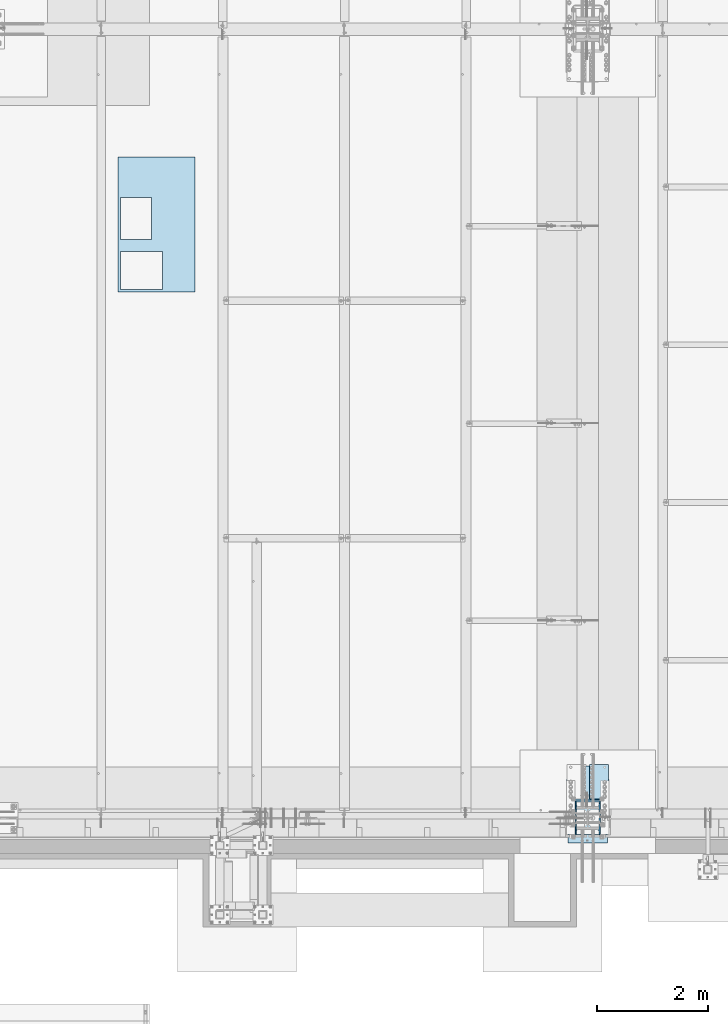
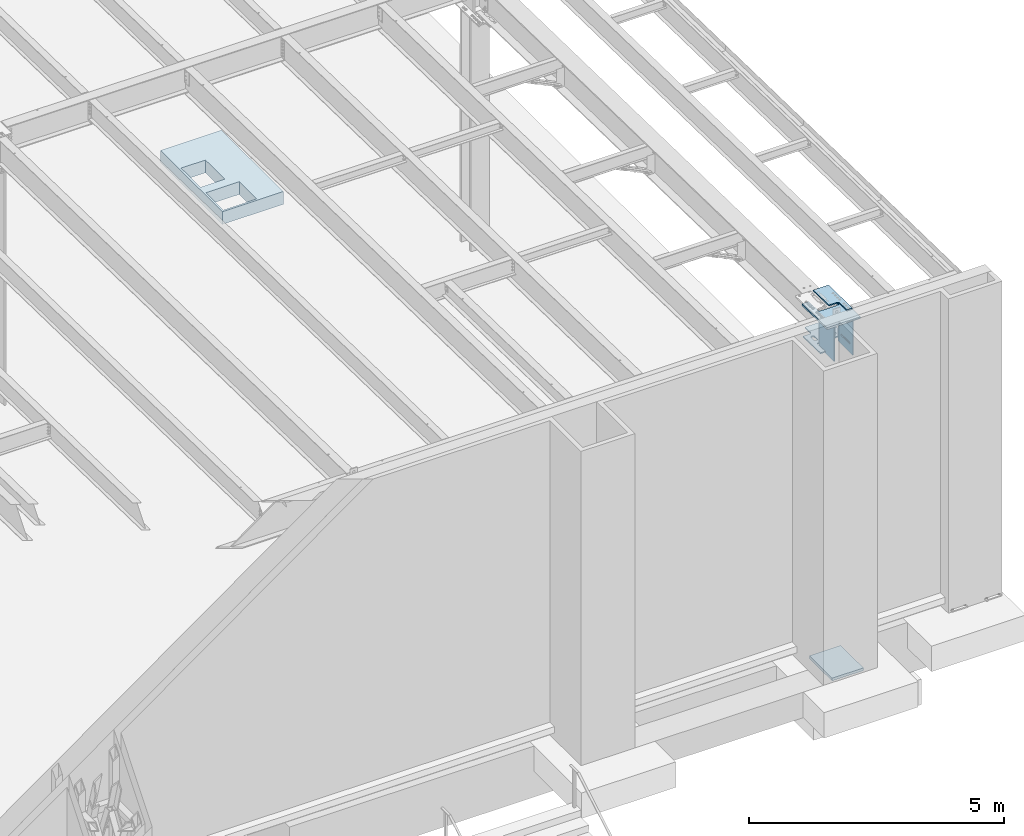
# One storey, part 1415 of 1763: 7 plates, 4 elements without a shape of their own.
"""IFC2X3 building model written with IfcOpenShell, lengths in millimetres."""

from ifc_helpers import new_model, si_unit, frame, origin_with_axes, place, context, subcontext, project, spatial, faceted_brep, material, type_object, element, aggregate, save


model = new_model("IFC2X3")

# Units and contexts
model_context = context("Model", 3, precision=1e-05, world=origin_with_axes())
body_context = subcontext(model_context, "Body", "Model", "MODEL_VIEW")
ifc_project = project(units=[si_unit("LENGTHUNIT", "METRE", prefix="MILLI"), si_unit("AREAUNIT", "SQUARE_METRE"), si_unit("VOLUMEUNIT", "CUBIC_METRE"), si_unit("MASSUNIT", "GRAM", prefix="KILO"), si_unit("TIMEUNIT", "SECOND"), si_unit("PLANEANGLEUNIT", "RADIAN"), si_unit("SOLIDANGLEUNIT", "STERADIAN"), si_unit("THERMODYNAMICTEMPERATUREUNIT", "DEGREE_CELSIUS"), si_unit("LUMINOUSINTENSITYUNIT", "LUMEN")], contexts=[model_context])

# Site, building, storey
site_placement = place(None, origin_with_axes())
site = spatial("IfcSite", under=ifc_project, at=site_placement, CompositionType="ELEMENT")
building_placement = place(site_placement, origin_with_axes())
building = spatial("IfcBuilding", under=site, at=building_placement, Name="Undefined", CompositionType="ELEMENT")
storey_placement = place(building_placement, origin_with_axes())
storey = spatial("IfcBuildingStorey", under=building, at=storey_placement, Name="Undefined", CompositionType="ELEMENT", Elevation=0.0)

# Assembly, plate
assembly_1_placement = place(storey_placement, origin_with_axes())
assembly_1 = element("IfcElementAssembly", 1, at=assembly_1_placement, inside=storey, Name="B-BOX", AssemblyPlace="NOTDEFINED", PredefinedType="RIGID_FRAME")
ifc_material_1 = material(Name="STEEL/A36")
plate_type_1 = type_object("IfcPlateType", PredefinedType="NOTDEFINED")
plate_1_placement = place(assembly_1_placement, frame((-32463.0393836975, -4264.56192860603, 11747.5), z_axis=(0.0, 1.0, 0.0), x_axis=(1.0, 0.0, 0.0)))
plate_1 = element("IfcPlate", 2, at=plate_1_placement, type_object=plate_type_1, material=ifc_material_1, Name="B-BOX", context=body_context, shape_type="Brep", body=[
    faceted_brep([(596.899999999994, -152.4, 1691.12592269852), (596.899999999994, 152.4, 1691.12592269852), (596.899999999994, 152.4, 939.803901214145), (596.899999999994, -152.4, 939.803901214145), (44.4499877929629, 152.4, 939.803901214145), (44.4499877929629, -152.4, 939.803901214145), (44.4499877929629, 152.4, 1695.45388175919), (44.4499877929629, -152.4, 1695.45388175919), (596.899999999994, 152.4, 1695.45388175919), (596.899999999994, -152.4, 1695.45388175919), (1377.94995117188, -152.4, 0.0), (0.0, -152.4, 0.0), (0.0, 152.4, 0.0), (1377.94995117188, 152.4, 0.0), (1377.94995117188, -152.4, 2422.52490234375), (1377.94995117188, 152.4, 2422.52490234375), (0.0, -152.4, 2422.52490234375), (0.0, 152.4, 2422.52490234375), (44.4499999999971, -152.4, 44.4499999999971), (44.4500244140654, -152.4, 723.903857421872), (800.091015625003, -152.4, 723.903857421872), (800.091015625003, -152.4, 44.4499999999971), (44.4499999999971, 152.4, 44.4499999999971), (44.4500244140654, 152.4, 723.903857421872), (800.091015625003, 152.4, 44.4499999999971), (800.091015625003, 152.4, 723.903857421872)], [[[0, 1, 2, 3]], [[3, 2, 4, 5]], [[5, 4, 6, 7]], [[7, 6, 8, 9]], [[9, 8, 1, 0]], [[10, 11, 12, 13]], [[14, 10, 13, 15]], [[16, 14, 15, 17]], [[11, 16, 17, 12]], [[10, 14, 16, 11], [3, 5, 7, 9, 0], [18, 19, 20, 21]], [[18, 22, 23, 19]], [[21, 24, 22, 18]], [[20, 25, 24, 21]], [[19, 23, 25, 20]], [[15, 13, 12, 17], [4, 2, 1, 8, 6], [22, 24, 25, 23]]]),
])
aggregate(assembly_1, [plate_1])

assembly_2_placement = place(storey_placement, origin_with_axes())
assembly_2 = element("IfcElementAssembly", 3, at=assembly_2_placement, inside=storey, Name="PLATE", AssemblyPlace="NOTDEFINED", PredefinedType="RIGID_FRAME")
ifc_material_2 = material(Name="STEEL/A572-50")
plate_type_2 = type_object("IfcPlateType", PredefinedType="NOTDEFINED")
plate_2_placement = place(assembly_2_placement, frame((-23653.1872981124, -13701.0606507006, 12218.6783026612), z_axis=(0.0, 0.999781542776098, -0.0209013569953182), x_axis=(-1.0, 0.0, 0.0)))
plate_2 = element("IfcPlate", 4, at=plate_2_placement, type_object=plate_type_2, material=ifc_material_2, Name="PLATE", context=body_context, shape_type="Brep", body=[
    faceted_brep([(123.824992193364, -14.2875000000113, 3.63797880709171e-12), (123.824992193364, 14.2875000000113, -5.45696821063757e-12), (123.82499219336, 14.287500000104, 285.760002489747), (123.82499219336, -14.2874999999167, 285.760002489757), (127.20854703131, 14.2875000001113, 302.77028135038), (127.20854703131, -14.2874999999112, 302.770281350391), (136.844095993078, 14.287500000115, 317.190899453044), (136.844095993078, -14.2874999999058, 317.190899453055), (151.264714095705, 14.2875000001186, 326.826448414837), (151.264714095705, -14.287499999904, 326.826448414846), (168.274992956296, 14.2875000001204, 330.210003252796), (168.274992956296, -14.2874999999021, 330.210003252805), (346.075022710938, -14.2874999999021, 330.210003252816), (346.075042724609, 14.2875000001204, 330.210003252807), (0.0, -14.2875000000058, 0.0), (-3.63797880709171e-12, -14.2874999997002, 946.190063477328), (-3.63797880709171e-12, 14.2875000003223, 946.190063477319), (0.0, 14.2875000000058, 0.0), (346.075042724609, -14.2874999997002, 946.190063477328), (346.075042724609, 14.2875000003223, 946.190063477319)], [[[0, 1, 2, 3]], [[3, 2, 4, 5]], [[5, 4, 6, 7]], [[7, 6, 8, 9]], [[9, 8, 10, 11]], [[12, 11, 10, 13]], [[14, 15, 16, 17]], [[15, 18, 19, 16]], [[19, 18, 12, 13]], [[8, 6, 4, 2, 1, 17, 16, 19, 13, 10]], [[14, 17, 1, 0]], [[18, 15, 14, 0, 3, 5, 7, 9, 11, 12]]]),
])
aggregate(assembly_2, [plate_2])

assembly_3_placement = place(storey_placement, origin_with_axes())
assembly_3 = element("IfcElementAssembly", 5, at=assembly_3_placement, inside=storey, Name="PLATE", AssemblyPlace="NOTDEFINED", PredefinedType="RIGID_FRAME")
plate_type_3 = type_object("IfcPlateType", PredefinedType="NOTDEFINED")
plate_3_placement = place(assembly_3_placement, frame((-24389.7220768876, -12781.3898005286, 11396.0012146675), z_axis=(1.0, 0.0, 0.0), x_axis=(0.0, -0.999781542838788, 0.0209013539966307)))
plate_3 = element("IfcPlate", 6, at=plate_3_placement, type_object=plate_type_3, material=ifc_material_2, Name="PLATE", context=body_context, shape_type="Brep", body=[
    faceted_brep([(518.787561500822, -14.2875000001823, 138.548366267998), (518.787561500831, 14.2874999998403, 138.548366267998), (513.150367974609, 14.2874999998421, 127.484751031894), (513.1503679746, -14.2875000001804, 127.484751031894), (504.37023321069, 14.2874999998457, 118.704616267998), (504.370233210682, -14.2875000001786, 118.704616267998), (493.306617974562, 14.2874999998476, 113.067422741788), (493.306617974551, -14.287500000175, 113.067422741788), (481.042506010277, 14.287499999853, 111.124978232252), (481.042506010266, -14.2875000001713, 111.124978232252), (382.617502958279, 14.2874999998839, 111.124978232252), (382.61750295827, -14.2875000001386, 111.124978232252), (370.353390993994, 14.2874999998894, 113.067422741788), (370.353390993985, -14.287500000135, 113.067422741788), (359.289775757867, 14.287499999893, 118.704616267998), (359.289775757856, -14.2875000001313, 118.704616267998), (350.509640993945, 14.2874999998949, 127.484751031894), (350.509640993936, -14.2875000001259, 127.484751031894), (344.872447467724, 14.2874999998985, 138.548366267998), (344.872447467713, -14.2875000001259, 138.548366267998), (342.930002958185, 14.2874999998967, 150.812478232252), (342.930002958175, -14.2875000001241, 150.812478232252), (344.872447467726, 14.2874999998985, 163.07659019651), (344.872447467715, -14.2875000001259, 163.07659019651), (350.509640993947, 14.2874999998949, 174.14020543261), (350.509640993938, -14.2875000001259, 174.14020543261), (359.289775757868, 14.287499999893, 182.920340196506), (359.289775757858, -14.2875000001313, 182.920340196506), (370.353390993996, 14.2874999998894, 188.557533722716), (370.353390993987, -14.287500000135, 188.557533722716), (382.617502958281, 14.2874999998839, 190.499978232252), (382.617502958272, -14.2875000001386, 190.499978232252), (481.042506010279, 14.287499999853, 190.499978232245), (481.042506010268, -14.2875000001713, 190.499978232245), (493.306617974564, 14.2874999998476, 188.557533722709), (493.306617974553, -14.287500000175, 188.557533722709), (504.370233210691, 14.2874999998457, 182.920340196502), (504.370233210682, -14.2875000001786, 182.920340196502), (513.150367974609, 14.2874999998421, 174.140205432603), (513.150367974602, -14.2875000001804, 174.140205432603), (518.787561500831, 14.2874999998403, 163.076590196502), (518.787561500823, -14.2875000001823, 163.076590196502), (520.730006010372, 14.2874999998385, 150.812478232245), (520.730006010364, -14.2875000001841, 150.812478232245), (255.262572580925, -14.287500000095, 163.076590196513), (255.262572580932, 14.2874999999258, 163.076590196513), (257.205017090471, 14.2874999999276, 150.812478232256), (257.205017090464, -14.2875000000986, 150.812478232256), (249.625379054703, -14.2875000000931, 174.140205432614), (249.625379054711, 14.2874999999294, 174.140205432614), (240.845244290782, -14.2875000000895, 182.920340196513), (240.845244290793, 14.2874999999312, 182.920340196513), (229.781629054653, -14.2875000000877, 188.55753372272), (229.781629054663, 14.2874999999349, 188.55753372272), (217.517517090368, -14.287500000084, 190.499978232256), (217.517517090379, 14.2874999999385, 190.499978232256), (-3.63797880709171e-12, -14.2875000000131, 190.499978232259), (5.45696821063757e-12, 14.2875000000113, 190.499978232259), (-3.63797880709171e-12, -14.2875000000131, 533.33478088379), (5.45696821063757e-12, 14.2875000000113, 533.33478088379), (217.517517090364, -14.287500000084, 533.33478088379), (217.517517090375, 14.2874999999385, 533.33478088379), (229.781629054649, -14.2875000000877, 535.277225393325), (229.78162905466, 14.2874999999349, 535.277225393325), (240.845244290778, -14.2875000000895, 540.914418919532), (240.845244290789, 14.2874999999312, 540.914418919532), (249.6253790547, -14.2875000000931, 549.694553683432), (249.625379054707, 14.2874999999294, 549.694553683432), (255.262572580921, -14.287500000095, 560.758168919532), (255.262572580928, 14.2874999999258, 560.758168919532), (257.20501709046, -14.2875000000968, 573.02228088379), (257.205017090468, 14.2874999999276, 573.02228088379), (257.20501709046, -14.2875000000968, 723.834777832031), (257.205017090468, 14.2874999999276, 723.834777832031), (936.664978028093, -14.2875000003205, 723.834777832031), (936.664978028102, 14.287499999702, 723.834777832031), (936.664978028093, -14.2875000003205, 612.709786581861), (936.664978028102, 14.287499999702, 612.709786581861), (646.14250601144, -14.2875000002259, 612.709786581869), (646.142506011451, 14.2874999997985, 612.709786581869), (633.878394047155, -14.2875000002205, 610.767342072333), (633.878394047166, 14.2874999998003, 610.767342072333), (622.814778811027, -14.287500000215, 605.130148546123), (622.814778811036, 14.2874999998057, 605.130148546123), (614.034644047108, -14.2875000002132, 596.350013782227), (614.034644047117, 14.2874999998094, 596.350013782227), (608.397450520886, -14.2875000002132, 585.286398546123), (608.397450520895, 14.2874999998112, 585.286398546123), (606.455006011345, -14.2875000002114, 573.022286581869), (606.455006011354, 14.2874999998112, 573.022286581869), (606.455006011345, -14.2875000002114, 150.812478232252), (606.455006011354, 14.2874999998112, 150.812478232252), (608.397450520886, -14.2875000002132, 138.548366267998), (608.397450520895, 14.2874999998112, 138.548366267998), (614.034644047108, -14.2875000002132, 127.484751031894), (614.034644047117, 14.2874999998094, 127.484751031894), (622.814778811027, -14.287500000215, 118.704616267998), (622.814778811036, 14.2874999998057, 118.704616267998), (633.878394047155, -14.2875000002205, 113.067422741788), (633.878394047164, 14.2874999998003, 113.067422741788), (646.14250601144, -14.2875000002259, 111.124978232252), (646.142506011451, 14.2874999997985, 111.124978232252), (936.664978028093, -14.2875000003205, 111.124978232252), (936.664978028102, 14.287499999702, 111.124978232252), (936.664978028093, -14.2875000003205, 7.27595761418343e-12), (936.664978028102, 14.287499999702, 7.27595761418343e-12), (257.205017090464, -14.2875000000986, 3.63797880709171e-12), (257.205017090471, 14.2874999999276, 3.63797880709171e-12), (513.1503679746, -14.2875000001804, 549.694559381522), (504.370233210682, -14.2875000001786, 540.914424617626), (493.306617974551, -14.287500000175, 535.277231091415), (481.042506010266, -14.2875000001713, 533.33478658188), (382.61750295827, -14.2875000001386, 533.33478658188), (370.353390993985, -14.287500000135, 535.277231091415), (359.289775757856, -14.2875000001313, 540.914424617626), (350.509640993936, -14.2875000001259, 549.694559381522), (344.872447467713, -14.2875000001259, 560.758174617626), (342.930002958175, -14.2875000001241, 573.02228658188), (344.872447467715, -14.2875000001259, 585.286398546134), (350.509640993938, -14.2875000001259, 596.350013782238), (359.289775757858, -14.2875000001313, 605.130148546134), (370.353390993987, -14.287500000135, 610.767342072344), (382.617502958272, -14.2875000001386, 612.70978658188), (481.042506010268, -14.2875000001713, 612.709786581872), (493.306617974553, -14.287500000175, 610.767342072337), (504.370233210682, -14.2875000001786, 605.13014854613), (513.150367974602, -14.2875000001804, 596.35001378223), (518.787561500823, -14.2875000001823, 585.28639854613), (520.730006010364, -14.2875000001841, 573.022286581872), (518.787561500822, -14.2875000001823, 560.758174617626), (513.150367974609, 14.2874999998421, 596.35001378223), (518.787561500831, 14.2874999998403, 585.28639854613), (504.370233210691, 14.2874999998457, 605.13014854613), (493.306617974564, 14.2874999998476, 610.767342072337), (481.042506010279, 14.287499999853, 612.709786581872), (382.617502958281, 14.2874999998839, 612.70978658188), (370.353390993996, 14.2874999998894, 610.767342072344), (359.289775757868, 14.287499999893, 605.130148546134), (350.509640993947, 14.2874999998949, 596.350013782238), (344.872447467726, 14.2874999998985, 585.286398546134), (342.930002958185, 14.2874999998967, 573.02228658188), (344.872447467724, 14.2874999998985, 560.758174617626), (350.509640993945, 14.2874999998949, 549.694559381522), (359.289775757867, 14.287499999893, 540.914424617626), (370.353390993994, 14.2874999998894, 535.277231091415), (382.617502958279, 14.2874999998839, 533.33478658188), (481.042506010277, 14.287499999853, 533.33478658188), (493.306617974562, 14.2874999998476, 535.277231091415), (504.37023321069, 14.2874999998457, 540.914424617626), (513.150367974609, 14.2874999998421, 549.694559381522), (518.787561500831, 14.2874999998403, 560.758174617626), (520.730006010372, 14.2874999998385, 573.022286581872)], [[[0, 1, 2, 3]], [[3, 2, 4, 5]], [[5, 4, 6, 7]], [[7, 6, 8, 9]], [[9, 8, 10, 11]], [[11, 10, 12, 13]], [[13, 12, 14, 15]], [[15, 14, 16, 17]], [[17, 16, 18, 19]], [[19, 18, 20, 21]], [[21, 20, 22, 23]], [[23, 22, 24, 25]], [[25, 24, 26, 27]], [[27, 26, 28, 29]], [[29, 28, 30, 31]], [[31, 30, 32, 33]], [[33, 32, 34, 35]], [[35, 34, 36, 37]], [[37, 36, 38, 39]], [[39, 38, 40, 41]], [[41, 40, 42, 43]], [[43, 42, 1, 0]], [[44, 45, 46, 47]], [[48, 49, 45, 44]], [[50, 51, 49, 48]], [[52, 53, 51, 50]], [[54, 55, 53, 52]], [[56, 57, 55, 54]], [[58, 59, 57, 56]], [[60, 61, 59, 58]], [[62, 63, 61, 60]], [[64, 65, 63, 62]], [[66, 67, 65, 64]], [[68, 69, 67, 66]], [[70, 71, 69, 68]], [[72, 73, 71, 70]], [[74, 75, 73, 72]], [[75, 74, 76, 77]], [[76, 78, 79, 77]], [[80, 81, 79, 78]], [[82, 83, 81, 80]], [[84, 85, 83, 82]], [[86, 87, 85, 84]], [[88, 89, 87, 86]], [[90, 91, 89, 88]], [[92, 93, 91, 90]], [[94, 95, 93, 92]], [[96, 97, 95, 94]], [[98, 99, 97, 96]], [[100, 101, 99, 98]], [[102, 103, 101, 100]], [[104, 105, 103, 102]], [[105, 104, 106, 107]], [[47, 46, 107, 106]], [[104, 102, 100, 98, 96, 94, 92, 90, 88, 86, 84, 82, 80, 78, 76, 74, 72, 70, 68, 66, 64, 62, 60, 58, 56, 54, 52, 50, 48, 44, 47, 106], [3, 5, 7, 9, 11, 13, 15, 17, 19, 21, 23, 25, 27, 29, 31, 33, 35, 37, 39, 41, 43, 0], [108, 109, 110, 111, 112, 113, 114, 115, 116, 117, 118, 119, 120, 121, 122, 123, 124, 125, 126, 127, 128, 129]], [[126, 130, 131, 127]], [[125, 132, 130, 126]], [[124, 133, 132, 125]], [[123, 134, 133, 124]], [[122, 135, 134, 123]], [[121, 136, 135, 122]], [[120, 137, 136, 121]], [[119, 138, 137, 120]], [[118, 139, 138, 119]], [[117, 140, 139, 118]], [[116, 141, 140, 117]], [[115, 142, 141, 116]], [[114, 143, 142, 115]], [[113, 144, 143, 114]], [[112, 145, 144, 113]], [[111, 146, 145, 112]], [[110, 147, 146, 111]], [[109, 148, 147, 110]], [[108, 149, 148, 109]], [[129, 150, 149, 108]], [[128, 151, 150, 129]], [[127, 131, 151, 128]], [[49, 51, 53, 55, 57, 59, 61, 63, 65, 67, 69, 71, 73, 75, 77, 79, 81, 83, 85, 87, 89, 91, 93, 95, 97, 99, 101, 103, 105, 107, 46, 45], [38, 36, 34, 32, 30, 28, 26, 24, 22, 20, 18, 16, 14, 12, 10, 8, 6, 4, 2, 1, 42, 40], [130, 132, 133, 134, 135, 136, 137, 138, 139, 140, 141, 142, 143, 144, 145, 146, 147, 148, 149, 150, 151, 131]]]),
])
aggregate(assembly_3, [plate_3])

# Assembly, plates
assembly_4_placement = place(storey_placement, origin_with_axes())
assembly_4 = element("IfcElementAssembly", 7, at=assembly_4_placement, inside=storey, Name="COLUMN", AssemblyPlace="NOTDEFINED", PredefinedType="RIGID_FRAME")
plate_type_4 = type_object("IfcPlateType", PredefinedType="NOTDEFINED")
plate_4_placement = place(assembly_4_placement, frame((-24242.1497736984, -14006.5123346154, 12222.6418484825), z_axis=(0.0, 1.0, 0.0), x_axis=(0.0, 0.0, -1.0)))
plate_4 = element("IfcPlate", 8, at=plate_4_placement, type_object=plate_type_4, material=ifc_material_2, Name="PLATE", context=body_context, shape_type="Brep", body=[
    faceted_brep([(873.35876464821, -11.1124999995336, 581.025024414414), (873.358764648443, -11.1124999995336, 4.42014425061643e-10), (873.358764648432, 11.1125000004649, 4.42014425061643e-10), (873.358764648197, 11.1125000004649, 581.025024414414), (68.479827814288, -11.1124999999593, 581.025080663496), (56.3329587030403, -11.1124999999702, 2.91038304567337e-11), (56.3329585474658, 11.112500000032, 2.91038304567337e-11), (68.4798276587135, 11.1125000000393, 581.025080663496)], [[[0, 1, 2, 3]], [[1, 0, 4, 5]], [[2, 1, 5, 6]], [[3, 2, 6, 7]], [[0, 3, 7, 4]], [[6, 5, 4, 7]]]),
])
plate_5_placement = place(assembly_4_placement, frame((-23813.5247736984, -14006.5123346154, 12222.6418486431), z_axis=(0.0, 1.0, 0.0), x_axis=(0.0, 0.0, -1.0)))
plate_5 = element("IfcPlate", 9, at=plate_5_placement, type_object=plate_type_4, material=ifc_material_2, Name="PLATE", context=body_context, shape_type="Brep", body=[
    faceted_brep([(79.0839983280657, -11.112499995179, 24.9299180232283), (56.8638532941295, 11.112500000032, 25.3944507987235), (56.8638534496367, -11.1124999999665, 25.3944507954711), (90.1664229911403, -11.1124999947606, 555.039086486202), (67.9462779575169, 11.1125000000393, 555.50361926169), (67.9462781130242, -11.1124999999629, 555.503619258438), (68.479827814288, -11.1124999999593, 581.025080663496), (68.4798276587135, 11.1125000000393, 581.025080663496), (873.35876464821, -11.1124999995336, 581.025024414414), (873.358764648197, 11.1125000004649, 581.025024414414), (873.358764648443, -11.1124999995336, 4.42014425061643e-10), (873.358764648432, 11.1125000004649, 4.42014425061643e-10), (56.3329587030403, -11.1124999999702, 2.91038304567337e-11), (56.3329585474658, 11.112500000032, 2.91038304567337e-11), (676.209604523568, 11.1125000003594, 466.180282409643), (672.089428069179, 11.1125000003558, 468.933296330721), (667.229348555968, 11.1125000003558, 469.90002627761), (645.004348174505, 11.1125000003449, 469.900026388734), (640.144268651624, 11.1125000003412, 468.933296490448), (636.024092169706, 11.1125000003376, 466.18028261057), (633.271078248628, 11.1125000003376, 462.060106156183), (632.304348301739, 11.1125000003376, 457.20002664297), (632.304346634857, 11.1125000003376, 123.825001847437), (633.271076533145, 11.1125000003376, 118.96492232456), (636.024090413022, 11.1125000003376, 114.84474584264), (640.144266867412, 11.1125000003412, 112.09173192156), (645.004346380621, 11.1125000003449, 111.125001974671), (667.229346762091, 11.1125000003558, 111.125001863547), (672.089426284972, 11.1125000003558, 112.091731761833), (676.20960276689, 11.1125000003594, 114.844745641711), (678.96261668797, 11.1125000003594, 118.9649220961), (679.929346634857, 11.1125000003594, 123.825001609312), (679.929348301732, 11.1125000003594, 457.200026404844), (678.962618403446, 11.1125000003594, 462.060105927725), (678.96261855902, -11.1124999996391, 462.060105927725), (679.929348457306, -11.1124999996391, 457.200026404844), (676.209604679143, -11.1124999996391, 466.180282409643), (672.089428224755, -11.1124999996428, 468.933296330721), (667.229348711542, -11.1124999996428, 469.90002627761), (645.00434833008, -11.1124999996573, 469.900026388734), (640.1442688072, -11.1124999996609, 468.933296490448), (636.02409232528, -11.1124999996646, 466.18028261057), (633.271078404203, -11.1124999996646, 462.060106156183), (632.304348457314, -11.1124999996646, 457.20002664297), (632.304346790432, -11.1124999996646, 123.825001847437), (633.271076688719, -11.1124999996646, 118.96492232456), (636.024090568597, -11.1124999996646, 114.84474584264), (640.144267022986, -11.1124999996609, 112.09173192156), (645.004346536198, -11.1124999996573, 111.125001974671), (667.229346917667, -11.1124999996428, 111.125001863547), (672.089426440547, -11.1124999996428, 112.091731761833), (676.209602922465, -11.1124999996391, 114.844745641711), (678.962616843544, -11.1124999996391, 118.9649220961), (679.929346790432, -11.1124999996391, 123.825001609312)], [[[0, 1, 2]], [[3, 4, 1, 0]], [[5, 4, 3]], [[6, 7, 4, 5]], [[8, 9, 7, 6]], [[8, 10, 11, 9]], [[11, 10, 12, 13]], [[13, 12, 2, 1]], [[7, 9, 11, 13, 1, 4], [14, 15, 16, 17, 18, 19, 20, 21, 22, 23, 24, 25, 26, 27, 28, 29, 30, 31, 32, 33]], [[34, 33, 32, 35]], [[36, 14, 33, 34]], [[37, 15, 14, 36]], [[38, 16, 15, 37]], [[39, 17, 16, 38]], [[40, 18, 17, 39]], [[41, 19, 18, 40]], [[42, 20, 19, 41]], [[43, 21, 20, 42]], [[44, 22, 21, 43]], [[45, 23, 22, 44]], [[46, 24, 23, 45]], [[47, 25, 24, 46]], [[48, 26, 25, 47]], [[49, 27, 26, 48]], [[50, 28, 27, 49]], [[51, 29, 28, 50]], [[52, 30, 29, 51]], [[53, 31, 30, 52]], [[35, 32, 31, 53]], [[2, 12, 10, 8, 6, 5, 3, 0], [52, 51, 50, 49, 48, 47, 46, 45, 44, 43, 42, 41, 40, 39, 38, 37, 36, 34, 35, 53]]]),
])
plate_type_5 = type_object("IfcPlateType", PredefinedType="NOTDEFINED")
plate_6_placement = place(assembly_4_placement, frame((-23646.8372737206, -13022.5623079374, 12167.9683616144), z_axis=(0.0, -0.999781542838788, 0.0209013539966307), x_axis=(-1.0, 0.0, 0.0)))
plate_6 = element("IfcPlate", 10, at=plate_6_placement, type_object=plate_type_5, material=ifc_material_2, Name="PLATE", context=body_context, shape_type="Brep", body=[
    faceted_brep([(155.574716445804, -22.2249999999276, -1.4915713109076e-10), (155.574716495823, 22.225000000064, -1.76441972143948e-10), (155.574718756801, 22.2250000002878, 378.142703854783), (155.57471870687, -22.2249999997039, 378.142703899208), (157.508178660093, 22.225000000295, 387.862862879319), (157.508178610169, -22.2249999997002, 387.862862923745), (163.014206510321, 22.2250000003023, 396.103215782719), (163.01420646039, -22.2249999996911, 396.103215827143), (171.254559479548, 22.2250000003096, 401.609243534418), (171.254559429621, -22.2249999996839, 401.609243578843), (180.974718527199, 22.2250000003132, 403.542703321491), (180.974718477271, -22.2249999996802, 403.542703365916), (581.025000051945, 22.2250000004915, 403.542700930106), (581.025000002021, -22.224999999502, 403.542700974531), (590.745159076479, 22.2250000004951, 401.609241026819), (590.745159026552, -22.2249999994983, 401.609241071248), (598.985511979867, 22.2250000004969, 396.103213176602), (598.985511929935, -22.2249999994965, 396.103213221029), (604.491539731553, 22.2250000004933, 387.862860207377), (604.491539681625, -22.2249999995001, 387.8628602518), (606.42499946868, -22.2249999995038, 378.142701204148), (606.424999518607, 22.2250000004897, 378.142701159722), (606.424997257709, 22.2250000002659, -6.43922248855233e-10), (606.424997207694, -22.2249999997293, -6.16637407802045e-10), (0.0, -22.2250000000022, 1.45519152283669e-11), (3.48700268659741e-08, -22.2249999994165, 984.212097167838), (3.48409230355173e-08, 22.225000000577, 984.212097167809), (0.0, 22.2249999999985, -1.45519152283669e-11), (762.000000000928, -22.22499999908, 984.212097167831), (762.000000000899, 22.2250000009153, 984.212097167801), (762.000000000015, -22.2249999996584, -7.80346454121172e-10), (761.999999999985, 22.2250000003351, -8.0763129517436e-10)], [[[0, 1, 2, 3]], [[3, 2, 4, 5]], [[5, 4, 6, 7]], [[7, 6, 8, 9]], [[9, 8, 10, 11]], [[11, 10, 12, 13]], [[13, 12, 14, 15]], [[15, 14, 16, 17]], [[17, 16, 18, 19]], [[20, 21, 22, 23]], [[19, 18, 21, 20]], [[24, 25, 26, 27]], [[25, 28, 29, 26]], [[28, 30, 31, 29]], [[31, 30, 23, 22]], [[16, 14, 12, 10, 8, 6, 4, 2, 1, 27, 26, 29, 31, 22, 21, 18]], [[24, 27, 1, 0]], [[30, 28, 25, 24, 0, 3, 5, 7, 9, 11, 13, 15, 17, 19, 20, 23]]]),
])
ifc_material_3 = material(Name="STEEL/A572-GR.50")
plate_type_6 = type_object("IfcPlateType", PredefinedType="NOTDEFINED")
plate_7_placement = place(assembly_4_placement, frame((-24383.4372736984, -13271.4999984633, 3879.8499902207), z_axis=(1.0, 0.0, 0.0), x_axis=(0.0, -1.0, 0.0)))
plate_7 = element("IfcPlate", 11, at=plate_7_placement, type_object=plate_type_6, material=ifc_material_3, Name="PLATE", context=body_context, shape_type="Brep", body=[
    faceted_brep([(-4.54747350886464e-13, -31.7499999999964, 0.0), (0.0, -31.75, 711.200012207031), (0.0, 31.75, 711.200012207031), (-5.91171556152403e-12, 31.7499999999891, 0.0), (889.0, -31.75, 711.200012207031), (889.0, 31.75, 711.200012207031), (889.0, -31.75, 0.0), (889.0, 31.75, 0.0)], [[[0, 1, 2, 3]], [[1, 4, 5, 2]], [[4, 6, 7, 5]], [[6, 0, 3, 7]], [[5, 7, 3, 2]], [[6, 4, 1, 0]]]),
])
aggregate(assembly_4, [plate_4, plate_5, plate_6, plate_7])

save(model, "model.ifc")
